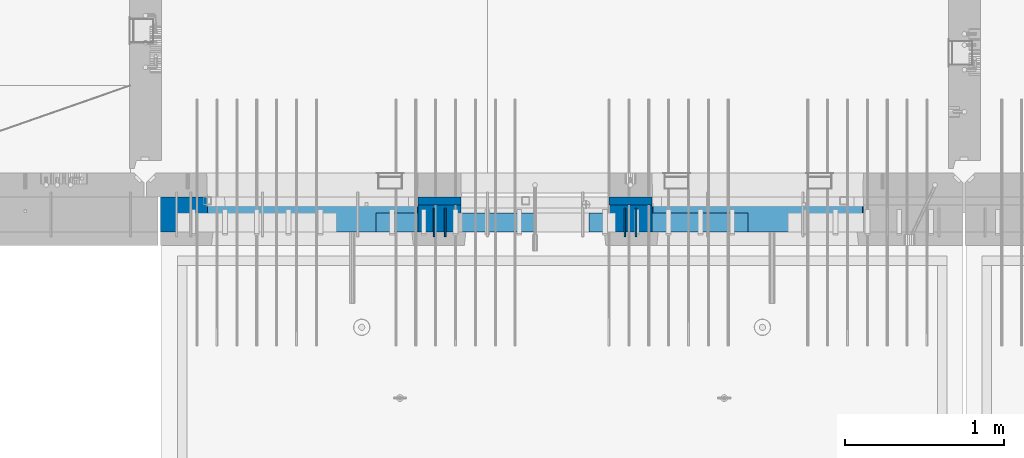
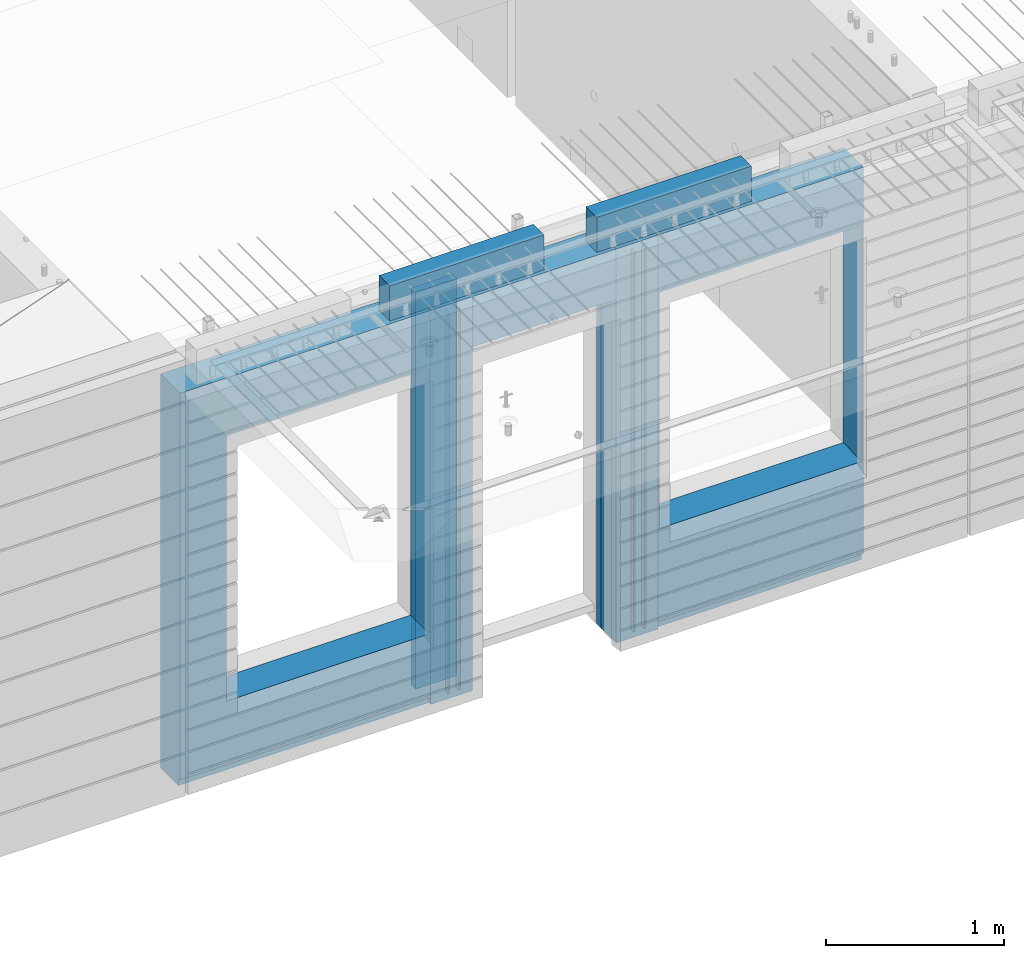
# One storey, part 230 of 352: 11 walls, 4 elements without a shape of their own.
"""IFC2X3 building model written with IfcOpenShell, lengths in millimetres."""

from ifc_helpers import new_model, si_unit, frame, origin_with_axes, place, context, subcontext, project, spatial, faceted_brep, material, type_object, element, aggregate, save


model = new_model("IFC2X3")

# Units and contexts
model_context = context("Model", 3, precision=1e-05, world=origin_with_axes())
body_context = subcontext(model_context, "Body", "Model", "MODEL_VIEW")
ifc_project = project(units=[si_unit("LENGTHUNIT", "METRE", prefix="MILLI"), si_unit("AREAUNIT", "SQUARE_METRE"), si_unit("VOLUMEUNIT", "CUBIC_METRE"), si_unit("MASSUNIT", "GRAM", prefix="KILO"), si_unit("TIMEUNIT", "SECOND"), si_unit("PLANEANGLEUNIT", "RADIAN"), si_unit("SOLIDANGLEUNIT", "STERADIAN"), si_unit("THERMODYNAMICTEMPERATUREUNIT", "DEGREE_CELSIUS"), si_unit("LUMINOUSINTENSITYUNIT", "LUMEN")], contexts=[model_context])

# Site, building, storey
site_placement = place(None, origin_with_axes())
site = spatial("IfcSite", under=ifc_project, at=site_placement, CompositionType="ELEMENT")
building_placement = place(site_placement, origin_with_axes())
building = spatial("IfcBuilding", under=site, at=building_placement, CompositionType="ELEMENT")
storey_placement = place(building_placement, origin_with_axes())
storey = spatial("IfcBuildingStorey", under=building, at=storey_placement, Name="6", CompositionType="ELEMENT", Elevation=0.0)

# Assembly, walls
assembly_1_placement = place(storey_placement, origin_with_axes())
assembly_1 = element("IfcElementAssembly", 1, at=assembly_1_placement, inside=storey, AssemblyPlace="NOTDEFINED", PredefinedType="REINFORCEMENT_UNIT")
ifc_material_1 = material(Name="Undefined")
wall_type_1 = type_object("IfcWallType", PredefinedType="NOTDEFINED")
wall_1_placement = place(assembly_1_placement, frame((18475.0, 7780.0, 98115.0), z_axis=(0.0, 0.0, 1.0), x_axis=(0.0, -1.0, 0.0)))
wall_1 = element("IfcWall", 2, at=wall_1_placement, type_object=wall_type_1, material=ifc_material_1, Name="(PD)", context=body_context, shape_type="Brep", body=[
    faceted_brep([(0.0, 5.0, -1300.0), (0.0, 5.0, 1300.0), (180.0, 5.0, 1300.0), (180.0, 5.0, -1300.0), (0.0, -5.0, 1300.0), (180.0, -5.0, 1300.0), (0.0, -5.0, -1300.0), (180.0, -5.0, -1300.0)], [[[0, 1, 2, 3]], [[1, 4, 5, 2]], [[4, 6, 7, 5]], [[6, 0, 3, 7]], [[5, 7, 3, 2]], [[6, 4, 1, 0]]]),
])
wall_2_placement = place(assembly_1_placement, frame((18545.0, 7780.0, 98115.0), z_axis=(0.0, 0.0, 1.0), x_axis=(0.0, -1.0, 0.0)))
wall_2 = element("IfcWall", 3, at=wall_2_placement, type_object=wall_type_1, material=ifc_material_1, Name="(PD)", context=body_context, shape_type="Brep", body=[
    faceted_brep([(0.0, 5.0, -1300.0), (0.0, 5.0, 1300.0), (180.0, 5.0, 1300.0), (180.0, 5.0, -1300.0), (0.0, -5.0, 1300.0), (180.0, -5.0, 1300.0), (0.0, -5.0, -1300.0), (180.0, -5.0, -1300.0)], [[[0, 1, 2, 3]], [[1, 4, 5, 2]], [[4, 6, 7, 5]], [[6, 0, 3, 7]], [[5, 7, 3, 2]], [[6, 4, 1, 0]]]),
])
wall_3_placement = place(assembly_1_placement, frame((19675.0, 7779.99999999997, 98115.0), z_axis=(0.0, 0.0, 1.0), x_axis=(0.0, -1.0, 0.0)))
wall_3 = element("IfcWall", 4, at=wall_3_placement, type_object=wall_type_1, material=ifc_material_1, Name="(PD)", context=body_context, shape_type="Brep", body=[
    faceted_brep([(0.0, 5.0, -1300.0), (0.0, 5.0, 1300.0), (180.0, 5.0, 1300.0), (180.0, 5.0, -1300.0), (0.0, -5.0, 1300.0), (180.0, -5.0, 1300.0), (0.0, -5.0, -1300.0), (180.0, -5.0, -1300.0)], [[[0, 1, 2, 3]], [[1, 4, 5, 2]], [[4, 6, 7, 5]], [[6, 0, 3, 7]], [[5, 7, 3, 2]], [[6, 4, 1, 0]]]),
])
wall_4_placement = place(assembly_1_placement, frame((19745.0, 7780.0, 98115.0), z_axis=(0.0, 0.0, 1.0), x_axis=(0.0, -1.0, 0.0)))
wall_4 = element("IfcWall", 5, at=wall_4_placement, type_object=wall_type_1, material=ifc_material_1, Name="(PD)", context=body_context, shape_type="Brep", body=[
    faceted_brep([(0.0, 5.0, -1300.0), (0.0, 5.0, 1300.0), (180.0, 5.0, 1300.0), (180.0, 5.0, -1300.0), (0.0, -5.0, 1300.0), (180.0, -5.0, 1300.0), (0.0, -5.0, -1300.0), (180.0, -5.0, -1300.0)], [[[0, 1, 2, 3]], [[1, 4, 5, 2]], [[4, 6, 7, 5]], [[6, 0, 3, 7]], [[5, 7, 3, 2]], [[6, 4, 1, 0]]]),
])

# Assemblies, walls
assembly_2_placement = place(storey_placement, origin_with_axes())
assembly_2 = element("IfcElementAssembly", 6, at=assembly_2_placement, inside=storey, AssemblyPlace="NOTDEFINED", PredefinedType="REINFORCEMENT_UNIT")
assembly_3_placement = place(assembly_2_placement, origin_with_axes())
assembly_3 = element("IfcElementAssembly", 7, at=assembly_3_placement, Name="Steel Assembly", AssemblyPlace="NOTDEFINED", PredefinedType="NOTDEFINED")
ifc_material_2 = material()
wall_type_2 = type_object("IfcWallType", PredefinedType="NOTDEFINED")
wall_5_placement = place(assembly_3_placement, frame((18109.9998568133, 7690.00021946163, 99590.0), z_axis=(0.0, 0.0, 1.0), x_axis=(1.0, 0.0, 0.0)))
wall_5 = element("IfcWall", 8, at=wall_5_placement, type_object=wall_type_2, material=ifc_material_2, context=body_context, shape_type="Brep", body=[
    faceted_brep([(0.0, 60.0, -120.0), (0.0, 60.0, 120.0), (1000.0, 60.0, 120.0), (1000.0, 60.0, -120.0), (0.0, -60.0, 120.0), (1000.0, -60.0, 120.0), (0.0, -60.0, -120.0), (1000.0, -60.0, -120.0)], [[[0, 1, 2, 3]], [[1, 4, 5, 2]], [[4, 6, 7, 5]], [[6, 0, 3, 7]], [[5, 7, 3, 2]], [[6, 4, 1, 0]]]),
])
aggregate(assembly_3, [wall_5])
assembly_4_placement = place(assembly_2_placement, origin_with_axes())
assembly_4 = element("IfcElementAssembly", 9, at=assembly_4_placement, Name="Steel Assembly", AssemblyPlace="NOTDEFINED", PredefinedType="NOTDEFINED")
aggregate(assembly_2, [assembly_4, assembly_3])
wall_6_placement = place(assembly_4_placement, frame((19449.9998568133, 7690.00021946163, 99590.0), z_axis=(0.0, 0.0, 1.0), x_axis=(1.0, 0.0, 0.0)))
wall_6 = element("IfcWall", 10, at=wall_6_placement, type_object=wall_type_2, material=ifc_material_2, context=body_context, shape_type="Brep", body=[
    faceted_brep([(0.0, 60.0, -120.0), (0.0, 60.0, 120.0), (1000.0, 60.0, 120.0), (1000.0, 60.0, -120.0), (0.0, -60.0, 120.0), (1000.0, -60.0, 120.0), (0.0, -60.0, -120.0), (1000.0, -60.0, -120.0)], [[[0, 1, 2, 3]], [[1, 4, 5, 2]], [[4, 6, 7, 5]], [[6, 0, 3, 7]], [[5, 7, 3, 2]], [[6, 4, 1, 0]]]),
])
aggregate(assembly_4, [wall_6])

# Wall
ifc_material_3 = material(Name="CONCRETE/C35/45")
wall_type_3 = type_object("IfcWallType", PredefinedType="NOTDEFINED")
wall_7_placement = place(assembly_1_placement, frame((18645.0200381475, 7825.0, 98112.5), z_axis=(0.0, 0.0, 1.0), x_axis=(-1.0, 3.00000001838171e-08, 0.0)))
wall_7 = element("IfcWall", 11, at=wall_7_placement, type_object=wall_type_3, material=ifc_material_3, context=body_context, shape_type="Brep", body=[
    faceted_brep([(0.0, 25.0, -1357.5), (0.0, 25.0, 1357.5), (270.001908754726, 25.0, 1357.5), (270.001908754726, 25.0, -1357.5), (0.0, -25.0, 1357.5), (270.001908754726, -25.0, 1357.5), (0.0, -25.0, -1357.5), (270.001908754726, -25.0, -1357.5)], [[[0, 1, 2, 3]], [[1, 4, 5, 2]], [[4, 6, 7, 5]], [[6, 0, 3, 7]], [[5, 7, 3, 2]], [[6, 4, 1, 0]]]),
])

wall_8_placement = place(assembly_1_placement, frame((19845.0100381475, 7825.0, 98112.5), z_axis=(0.0, 0.0, 1.0), x_axis=(-1.0, 3.00000001838171e-08, 0.0)))
wall_8 = element("IfcWall", 12, at=wall_8_placement, type_object=wall_type_3, material=ifc_material_3, context=body_context, shape_type="Brep", body=[
    faceted_brep([(0.0, 25.0, -1357.5), (0.0, 25.0, 1357.5), (270.001908754726, 25.0, 1357.5), (270.001908754726, 25.0, -1357.5), (0.0, -25.0, 1357.5), (270.001908754726, -25.0, 1357.5), (0.0, -25.0, -1357.5), (270.001908754726, -25.0, -1357.5)], [[[0, 1, 2, 3]], [[1, 4, 5, 2]], [[4, 6, 7, 5]], [[6, 0, 3, 7]], [[5, 7, 3, 2]], [[6, 4, 1, 0]]]),
])

ifc_material_4 = material(Name="SPU")
wall_type_4 = type_object("IfcWallType", PredefinedType="NOTDEFINED")
wall_9_placement = place(assembly_1_placement, frame((18645.0100381475, 7715.0, 98102.5), z_axis=(0.0, 0.0, 1.0), x_axis=(-1.0, 3.00000001838171e-08, 0.0)))
wall_9 = element("IfcWall", 13, at=wall_9_placement, type_object=wall_type_4, material=ifc_material_4, context=body_context, shape_type="Brep", body=[
    faceted_brep([(0.0, 85.0, -1347.5), (0.0, 85.0, 1347.5), (270.001908754726, 85.0, 1347.5), (270.001908754726, 85.0, -1347.5), (0.0, -85.0, 1347.5), (270.001908754726, -85.0, 1347.5), (0.0, -85.0, -1347.5), (270.001908754726, -85.0, -1347.5)], [[[0, 1, 2, 3]], [[1, 4, 5, 2]], [[4, 6, 7, 5]], [[6, 0, 3, 7]], [[5, 7, 3, 2]], [[6, 4, 1, 0]]]),
])

wall_10_placement = place(assembly_1_placement, frame((19845.0100381475, 7715.0, 98102.5), z_axis=(0.0, 0.0, 1.0), x_axis=(-1.0, 3.00000001838171e-08, 0.0)))
wall_10 = element("IfcWall", 14, at=wall_10_placement, type_object=wall_type_4, material=ifc_material_4, context=body_context, shape_type="Brep", body=[
    faceted_brep([(0.0, 85.0, -1347.5), (0.0, 85.0, 1347.5), (270.001908754726, 85.0, 1347.5), (270.001908754726, 85.0, -1347.5), (0.0, -85.0, 1347.5), (270.001908754726, -85.0, 1347.5), (0.0, -85.0, -1347.5), (270.001908754726, -85.0, -1347.5)], [[[0, 1, 2, 3]], [[1, 4, 5, 2]], [[4, 6, 7, 5]], [[6, 0, 3, 7]], [[5, 7, 3, 2]], [[6, 4, 1, 0]]]),
])

ifc_material_5 = material(Name="COS5gt")
wall_type_5 = type_object("IfcWallType", PredefinedType="NOTDEFINED")
wall_11_placement = place(assembly_1_placement, frame((21175.0, 7740.0, 98102.5), z_axis=(0.0, 0.0, 1.0), x_axis=(-1.0, 3.00000001838171e-08, 0.0)))
wall_11 = element("IfcWall", 15, at=wall_11_placement, type_object=wall_type_5, material=ifc_material_5, context=body_context, shape_type="Brep", body=[
    faceted_brep([(4420.0, -110.0, 1347.5), (4420.0, 110.0, 1347.5), (2799.99187060721, 110.0, 1347.5), (2799.99187060721, -10.0, 1347.5), (2799.9818706072, -110.0, 1347.5), (4420.0, 110.0, -1297.5), (4420.0, 90.0, -1297.5), (2799.99187060721, 90.0, -1297.5), (2799.99187060721, 110.0, -1297.5), (4420.0, -110.0, -1347.5), (4420.0, 90.0, -1347.5), (2799.99187060721, 90.0, -1347.5), (2799.99187060721, -10.0, -1347.5), (2809.99937278789, 110.0, -862.5), (2839.99937278789, 110.0, -862.5), (4089.99937278789, 110.0, -862.5), (4119.99937278789, 110.0, -862.5), (4119.99937278789, 110.0, -857.5), (4119.99937278789, 110.0, 952.5), (2809.99937278789, 110.0, 952.5), (2809.99937278789, 110.0, -857.5), (2804.05342684194, -110.0, -868.445945945947), (2804.05342684194, -109.999999999999, 958.445945945947), (4125.94531873383, -110.0, -868.445945945947), (4125.94531873383, -109.999999999999, 958.445945945947), (2799.9818706072, -110.0, -1347.5), (1329.98996185248, -110.0, 1347.5), (1329.98996185248, -110.0, -1347.5), (1329.98996185248, -10.0, -1347.5), (1329.98996185248, -10.0, 1347.5), (0.0, -110.0, -1347.5), (0.0, 90.0, -1347.5), (1329.98996185248, 90.0, -1347.5), (0.0, 90.0, -1297.5), (0.0, 110.0, -1297.5), (1329.98996185248, 110.0, -1297.5), (1329.98996185248, 90.0, -1297.5), (0.0, -110.0, 1347.5), (0.0, 110.0, 1347.5), (1329.98996185248, 110.0, 1347.5), (10.0001357273395, 110.0, -662.5), (40.0001357273395, 110.0, -662.5), (1290.00013572734, 110.0, -662.5), (1320.00013572734, 110.0, -662.5), (1320.00013572734, 110.0, -657.5), (1320.00013572734, 110.0, 952.5), (10.0001357273395, 110.0, 952.5), (10.0001357273395, 110.0, -657.5), (4.05418978139278, -110.0, -668.445945945947), (4.05418978139278, -109.999999999999, 958.445945945947), (1325.94608167329, -110.0, -668.445945945947), (1325.94608167329, -109.999999999999, 958.445945945947), (1600.00051719707, -109.999999999999, 1002.5), (1599.99187060721, -110.0, 1347.5), (1599.99187060721, -10.0, 1347.5), (1600.00051719707, -10.0, 1002.5), (1600.00051719707, 110.0, 1002.5), (1599.99187060721, 110.0, 1347.5), (2529.98996185248, 110.0, 1347.5), (2529.98996185248, 110.0, 1002.5), (2529.98996185248, -10.0, 1347.5), (2529.98996185248, -10.0, 1002.5), (2529.97996185248, -110.0, 1347.5), (2529.97996185248, -109.999999999999, 1002.5)], [[[0, 1, 2, 3, 4]], [[5, 6, 7, 8]], [[1, 0, 9, 10, 6, 5]], [[6, 10, 11, 7]], [[2, 8, 7, 11, 12, 3]], [[1, 5, 8, 2], [13, 14, 15, 16, 17, 18, 19, 20]], [[21, 13, 20, 19, 22]], [[23, 16, 15, 14, 13, 21]], [[17, 16, 23, 24, 18]], [[22, 19, 18, 24]], [[9, 0, 4, 25], [23, 21, 22, 24]], [[11, 10, 9, 25, 12]], [[4, 3, 12, 25]], [[26, 27, 28, 29]], [[27, 30, 31, 32, 28]], [[33, 34, 35, 36]], [[31, 33, 36, 32]], [[30, 37, 38, 34, 33, 31]], [[38, 37, 26, 29, 39]], [[29, 28, 32, 36, 35, 39]], [[34, 38, 39, 35], [40, 41, 42, 43, 44, 45, 46, 47]], [[48, 40, 47, 46, 49]], [[50, 43, 42, 41, 40, 48]], [[44, 43, 50, 51, 45]], [[49, 46, 45, 51]], [[37, 30, 27, 26], [50, 48, 49, 51]], [[52, 53, 54, 55]], [[56, 57, 58, 59]], [[59, 58, 60, 61]], [[62, 63, 61, 60]], [[53, 52, 63, 62]], [[56, 59, 61, 63, 52, 55]], [[54, 57, 56, 55]], [[62, 60, 58, 57, 54, 53]]]),
])

aggregate(assembly_1, [wall_7, wall_9, wall_10, wall_1, wall_2, wall_8, wall_3, wall_4, wall_11])

save(model, "model.ifc")
